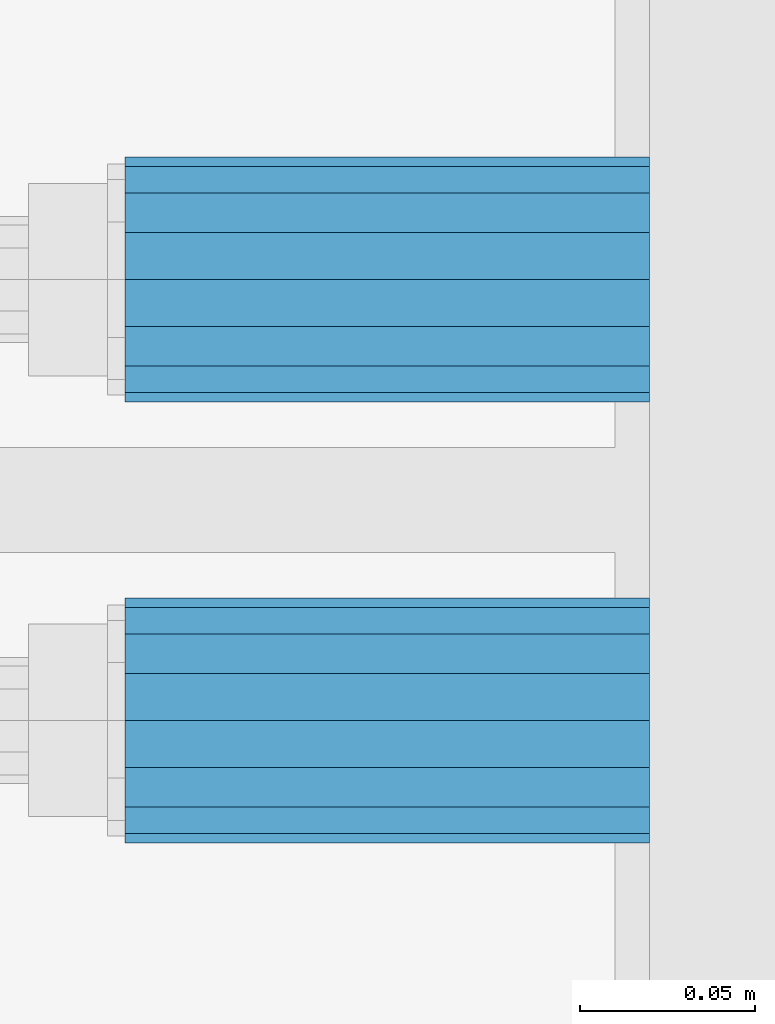
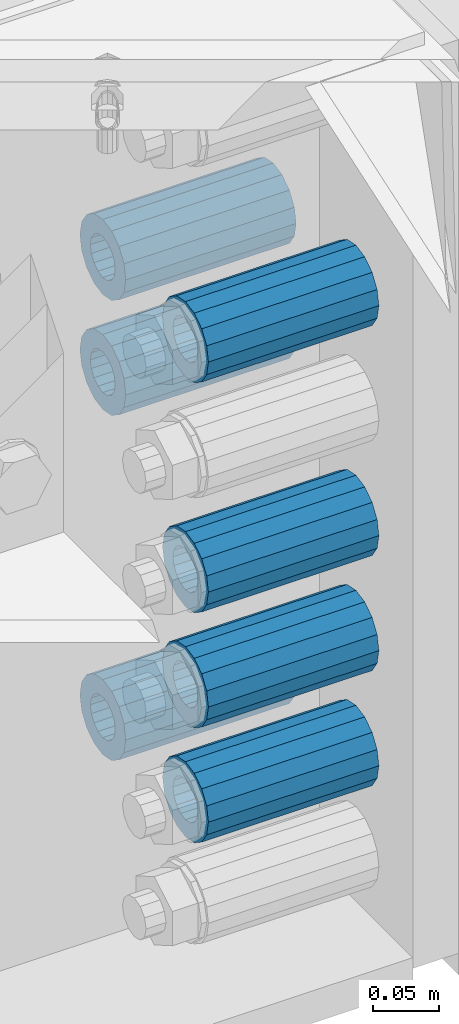
# One storey, part 163 of 257: 7 beams.
"""IFC2X3 building model written with IfcOpenShell, lengths in millimetres."""

from ifc_helpers import new_model, si_unit, frame, origin_with_axes, place, context, subcontext, project, spatial, faceted_brep, material, type_object, element, save


model = new_model("IFC2X3")

# Units and contexts
model_context = context("Model", 3, precision=1e-05, world=origin_with_axes())
body_context = subcontext(model_context, "Body", "Model", "MODEL_VIEW")
ifc_project = project(units=[si_unit("LENGTHUNIT", "METRE", prefix="MILLI"), si_unit("AREAUNIT", "SQUARE_METRE"), si_unit("VOLUMEUNIT", "CUBIC_METRE"), si_unit("MASSUNIT", "GRAM", prefix="KILO"), si_unit("TIMEUNIT", "SECOND"), si_unit("PLANEANGLEUNIT", "RADIAN"), si_unit("SOLIDANGLEUNIT", "STERADIAN"), si_unit("THERMODYNAMICTEMPERATUREUNIT", "DEGREE_CELSIUS"), si_unit("LUMINOUSINTENSITYUNIT", "LUMEN")], contexts=[model_context])

# Site, building, storey
site_placement = place(None, origin_with_axes())
site = spatial("IfcSite", under=ifc_project, at=site_placement, CompositionType="ELEMENT")
building_placement = place(site_placement, origin_with_axes())
building = spatial("IfcBuilding", under=site, at=building_placement, Name="Standard", CompositionType="ELEMENT")
storey_placement = place(building_placement, origin_with_axes())
storey = spatial("IfcBuildingStorey", under=building, at=storey_placement, Name="Undefined", CompositionType="ELEMENT", Elevation=0.0)

# Beams
ifc_material = material()
beam_type = type_object("IfcBeamType", PredefinedType="NOTDEFINED")
beam_1_placement = place(storey_placement, frame((59117.0, 3063.0, -285.0), z_axis=(0.0, 0.0, 1.0), x_axis=(1.0, 0.0, 0.0)))
element("IfcBeam", 1, at=beam_1_placement, inside=storey, type_object=beam_type, material=ifc_material, context=body_context, shape_type="Brep", body=[
    faceted_brep([(-1.3120632047503e-07, -18.9999999995493, -6.27187546342611e-09), (0.0, -17.5537111177146, 7.27098521493672), (150.0, -17.5537111177146, 7.27098521493672), (150.0, -19.0, 0.0), (0.0, -13.4350288425449, 13.4350288425444), (150.0, -13.4350288425449, 13.4350288425444), (0.0, -7.27098521493645, 17.5537111177144), (150.0, -7.27098521493645, 17.5537111177144), (-6.33792751614237e-09, 4.50654624728486e-10, 18.9999999937208), (150.0, 0.0, 19.0), (0.0, 7.27098521493645, 17.5537111177144), (150.0, 7.27098521493645, 17.5537111177144), (0.0, 13.4350288425449, 13.4350288425444), (150.0, 13.4350288425449, 13.4350288425444), (0.0, 17.5537111177146, 7.2709852149367), (150.0, 17.5537111177146, 7.2709852149367), (1.33208345687308e-07, 19.0000000004507, -6.27187546342611e-09), (150.0, 19.0, 0.0), (0.0, 17.5537111177146, -7.2709852149367), (150.0, 17.5537111177146, -7.2709852149367), (0.0, 13.4350288425449, -13.4350288425444), (150.0, 13.4350288425449, -13.4350288425444), (0.0, 7.27098521493645, -17.5537111177144), (150.0, 7.27098521493645, -17.5537111177144), (8.33983904158231e-09, 4.50654624728486e-10, -19.0000000062719), (150.0, 0.0, -19.0), (0.0, -7.27098521493645, -17.5537111177144), (150.0, -7.27098521493645, -17.5537111177144), (0.0, -13.4350288425449, -13.4350288425444), (150.0, -13.4350288425449, -13.4350288425444), (0.0, -17.5537111177146, -7.2709852149367), (150.0, -17.5537111177146, -7.2709852149367), (7.27595761418343e-12, -35.0, 0.0), (1.45519152283669e-11, -32.335783637895, -13.3939201327781), (150.0, -32.3357836378955, -13.3939201327782), (150.0, -35.0, 0.0), (7.27595761418343e-12, -24.7487373415292, -24.748737341529), (150.0, -24.7487373415288, -24.7487373415292), (7.27595761418343e-12, -13.3939201327781, -32.335783637895), (150.0, -13.3939201327785, -32.335783637895), (7.27595761418343e-12, 0.0, -35.0), (150.0, 0.0, -35.0), (7.27595761418343e-12, 13.3939201327782, -32.335783637895), (150.0, 13.3939201327785, -32.335783637895), (7.27595761418343e-12, 24.7487373415292, -24.748737341529), (150.0, 24.7487373415288, -24.7487373415292), (1.45519152283669e-11, 32.335783637895, -13.3939201327781), (150.0, 32.3357836378955, -13.3939201327781), (7.27595761418343e-12, 35.0, 0.0), (150.0, 35.0, 0.0), (7.27595761418343e-12, 32.335783637895, 13.3939201327782), (150.0, 32.3357836378955, 13.3939201327781), (7.27595761418343e-12, 24.7487373415292, 24.7487373415291), (150.0, 24.7487373415288, 24.7487373415292), (1.45519152283669e-11, 13.3939201327781, 32.335783637895), (150.0, 13.3939201327785, 32.335783637895), (1.45519152283669e-11, 0.0, 35.0000000000001), (150.0, 0.0, 35.0), (1.45519152283669e-11, -13.3939201327781, 32.335783637895), (150.0, -13.3939201327785, 32.335783637895), (7.27595761418343e-12, -24.7487373415292, 24.7487373415291), (150.0, -24.7487373415288, 24.7487373415292), (7.27595761418343e-12, -32.335783637895, 13.3939201327782), (150.0, -32.3357836378955, 13.3939201327781)], [[[0, 1, 2, 3]], [[1, 4, 5, 2]], [[4, 6, 7, 5]], [[6, 8, 9, 7]], [[8, 10, 11, 9]], [[10, 12, 13, 11]], [[12, 14, 15, 13]], [[14, 16, 17, 15]], [[16, 18, 19, 17]], [[18, 20, 21, 19]], [[20, 22, 23, 21]], [[22, 24, 25, 23]], [[24, 26, 27, 25]], [[26, 28, 29, 27]], [[28, 30, 31, 29]], [[30, 0, 3, 31]], [[32, 33, 34, 35]], [[33, 36, 37, 34]], [[36, 38, 39, 37]], [[38, 40, 41, 39]], [[40, 42, 43, 41]], [[42, 44, 45, 43]], [[44, 46, 47, 45]], [[46, 48, 49, 47]], [[48, 50, 51, 49]], [[50, 52, 53, 51]], [[52, 54, 55, 53]], [[54, 56, 57, 55]], [[56, 58, 59, 57]], [[58, 60, 61, 59]], [[60, 62, 63, 61]], [[62, 32, 35, 63]], [[37, 39, 41, 43, 45, 47, 49, 51, 53, 55, 57, 59, 61, 63, 35, 34], [5, 7, 9, 11, 13, 15, 17, 19, 21, 23, 25, 27, 29, 31, 3, 2]], [[62, 60, 58, 56, 54, 52, 50, 48, 46, 44, 42, 40, 38, 36, 33, 32], [30, 28, 26, 24, 22, 20, 18, 16, 14, 12, 10, 8, 6, 4, 1, 0]]]),
])
beam_2_placement = place(storey_placement, frame((59117.0, 2937.0, -285.0), z_axis=(0.0, 0.0, 1.0), x_axis=(1.0, 0.0, 0.0)))
element("IfcBeam", 2, at=beam_2_placement, inside=storey, type_object=beam_type, material=ifc_material, context=body_context, shape_type="Brep", body=[
    faceted_brep([(-1.3120632047503e-07, -18.9999999995493, -6.27187546342611e-09), (0.0, -17.5537111177146, 7.27098521493672), (150.0, -17.5537111177146, 7.27098521493672), (150.0, -19.0, 0.0), (0.0, -13.4350288425449, 13.4350288425444), (150.0, -13.4350288425449, 13.4350288425444), (0.0, -7.27098521493645, 17.5537111177144), (150.0, -7.27098521493645, 17.5537111177144), (-6.33792751614237e-09, 4.50654624728486e-10, 18.9999999937208), (150.0, 0.0, 19.0), (0.0, 7.27098521493645, 17.5537111177144), (150.0, 7.27098521493645, 17.5537111177144), (0.0, 13.4350288425449, 13.4350288425444), (150.0, 13.4350288425449, 13.4350288425444), (0.0, 17.5537111177146, 7.2709852149367), (150.0, 17.5537111177146, 7.2709852149367), (1.33208345687308e-07, 19.0000000004507, -6.27187546342611e-09), (150.0, 19.0, 0.0), (0.0, 17.5537111177146, -7.2709852149367), (150.0, 17.5537111177146, -7.2709852149367), (0.0, 13.4350288425449, -13.4350288425444), (150.0, 13.4350288425449, -13.4350288425444), (0.0, 7.27098521493645, -17.5537111177144), (150.0, 7.27098521493645, -17.5537111177144), (8.33983904158231e-09, 4.50654624728486e-10, -19.0000000062719), (150.0, 0.0, -19.0), (0.0, -7.27098521493645, -17.5537111177144), (150.0, -7.27098521493645, -17.5537111177144), (0.0, -13.4350288425449, -13.4350288425444), (150.0, -13.4350288425449, -13.4350288425444), (0.0, -17.5537111177146, -7.2709852149367), (150.0, -17.5537111177146, -7.2709852149367), (7.27595761418343e-12, -35.0, 0.0), (1.45519152283669e-11, -32.335783637895, -13.3939201327781), (150.0, -32.3357836378955, -13.3939201327782), (150.0, -35.0, 0.0), (7.27595761418343e-12, -24.7487373415292, -24.748737341529), (150.0, -24.7487373415288, -24.7487373415292), (7.27595761418343e-12, -13.3939201327781, -32.335783637895), (150.0, -13.3939201327785, -32.335783637895), (7.27595761418343e-12, 0.0, -35.0), (150.0, 0.0, -35.0), (7.27595761418343e-12, 13.3939201327782, -32.335783637895), (150.0, 13.3939201327785, -32.335783637895), (7.27595761418343e-12, 24.7487373415292, -24.748737341529), (150.0, 24.7487373415288, -24.7487373415292), (1.45519152283669e-11, 32.335783637895, -13.3939201327781), (150.0, 32.3357836378955, -13.3939201327781), (7.27595761418343e-12, 35.0, 0.0), (150.0, 35.0, 0.0), (7.27595761418343e-12, 32.335783637895, 13.3939201327782), (150.0, 32.3357836378955, 13.3939201327781), (7.27595761418343e-12, 24.7487373415292, 24.7487373415291), (150.0, 24.7487373415288, 24.7487373415292), (1.45519152283669e-11, 13.3939201327781, 32.335783637895), (150.0, 13.3939201327785, 32.335783637895), (1.45519152283669e-11, 0.0, 35.0000000000001), (150.0, 0.0, 35.0), (1.45519152283669e-11, -13.3939201327781, 32.335783637895), (150.0, -13.3939201327785, 32.335783637895), (7.27595761418343e-12, -24.7487373415292, 24.7487373415291), (150.0, -24.7487373415288, 24.7487373415292), (7.27595761418343e-12, -32.335783637895, 13.3939201327782), (150.0, -32.3357836378955, 13.3939201327781)], [[[0, 1, 2, 3]], [[1, 4, 5, 2]], [[4, 6, 7, 5]], [[6, 8, 9, 7]], [[8, 10, 11, 9]], [[10, 12, 13, 11]], [[12, 14, 15, 13]], [[14, 16, 17, 15]], [[16, 18, 19, 17]], [[18, 20, 21, 19]], [[20, 22, 23, 21]], [[22, 24, 25, 23]], [[24, 26, 27, 25]], [[26, 28, 29, 27]], [[28, 30, 31, 29]], [[30, 0, 3, 31]], [[32, 33, 34, 35]], [[33, 36, 37, 34]], [[36, 38, 39, 37]], [[38, 40, 41, 39]], [[40, 42, 43, 41]], [[42, 44, 45, 43]], [[44, 46, 47, 45]], [[46, 48, 49, 47]], [[48, 50, 51, 49]], [[50, 52, 53, 51]], [[52, 54, 55, 53]], [[54, 56, 57, 55]], [[56, 58, 59, 57]], [[58, 60, 61, 59]], [[60, 62, 63, 61]], [[62, 32, 35, 63]], [[37, 39, 41, 43, 45, 47, 49, 51, 53, 55, 57, 59, 61, 63, 35, 34], [5, 7, 9, 11, 13, 15, 17, 19, 21, 23, 25, 27, 29, 31, 3, 2]], [[62, 60, 58, 56, 54, 52, 50, 48, 46, 44, 42, 40, 38, 36, 33, 32], [30, 28, 26, 24, 22, 20, 18, 16, 14, 12, 10, 8, 6, 4, 1, 0]]]),
])
beam_3_placement = place(storey_placement, frame((59117.0, 2937.0, -499.0), z_axis=(0.0, 0.0, 1.0), x_axis=(1.0, 0.0, 0.0)))
element("IfcBeam", 3, at=beam_3_placement, inside=storey, type_object=beam_type, material=ifc_material, context=body_context, shape_type="Brep", body=[
    faceted_brep([(-1.3120632047503e-07, -18.9999999995493, -6.27187546342611e-09), (0.0, -17.5537111177146, 7.27098521493672), (150.0, -17.5537111177146, 7.27098521493672), (150.0, -19.0, 0.0), (0.0, -13.4350288425449, 13.4350288425444), (150.0, -13.4350288425449, 13.4350288425444), (0.0, -7.27098521493645, 17.5537111177144), (150.0, -7.27098521493645, 17.5537111177144), (-6.33792751614237e-09, 4.50654624728486e-10, 18.9999999937208), (150.0, 0.0, 19.0), (0.0, 7.27098521493645, 17.5537111177144), (150.0, 7.27098521493645, 17.5537111177144), (0.0, 13.4350288425449, 13.4350288425444), (150.0, 13.4350288425449, 13.4350288425444), (0.0, 17.5537111177146, 7.2709852149367), (150.0, 17.5537111177146, 7.2709852149367), (1.33208345687308e-07, 19.0000000004507, -6.27187546342611e-09), (150.0, 19.0, 0.0), (0.0, 17.5537111177146, -7.2709852149367), (150.0, 17.5537111177146, -7.2709852149367), (0.0, 13.4350288425449, -13.4350288425444), (150.0, 13.4350288425449, -13.4350288425444), (0.0, 7.27098521493645, -17.5537111177144), (150.0, 7.27098521493645, -17.5537111177144), (8.33983904158231e-09, 4.50654624728486e-10, -19.0000000062719), (150.0, 0.0, -19.0), (0.0, -7.27098521493645, -17.5537111177144), (150.0, -7.27098521493645, -17.5537111177144), (0.0, -13.4350288425449, -13.4350288425444), (150.0, -13.4350288425449, -13.4350288425444), (0.0, -17.5537111177146, -7.2709852149367), (150.0, -17.5537111177146, -7.2709852149367), (7.27595761418343e-12, -35.0, 0.0), (1.45519152283669e-11, -32.335783637895, -13.3939201327781), (150.0, -32.3357836378955, -13.3939201327782), (150.0, -35.0, 0.0), (7.27595761418343e-12, -24.7487373415292, -24.748737341529), (150.0, -24.7487373415288, -24.7487373415292), (7.27595761418343e-12, -13.3939201327781, -32.335783637895), (150.0, -13.3939201327785, -32.335783637895), (7.27595761418343e-12, 0.0, -35.0), (150.0, 0.0, -35.0), (7.27595761418343e-12, 13.3939201327782, -32.335783637895), (150.0, 13.3939201327785, -32.335783637895), (7.27595761418343e-12, 24.7487373415292, -24.748737341529), (150.0, 24.7487373415288, -24.7487373415292), (1.45519152283669e-11, 32.335783637895, -13.3939201327781), (150.0, 32.3357836378955, -13.3939201327781), (7.27595761418343e-12, 35.0, 0.0), (150.0, 35.0, 0.0), (7.27595761418343e-12, 32.335783637895, 13.3939201327782), (150.0, 32.3357836378955, 13.3939201327781), (7.27595761418343e-12, 24.7487373415292, 24.7487373415291), (150.0, 24.7487373415288, 24.7487373415292), (1.45519152283669e-11, 13.3939201327781, 32.335783637895), (150.0, 13.3939201327785, 32.335783637895), (1.45519152283669e-11, 0.0, 35.0000000000001), (150.0, 0.0, 35.0), (1.45519152283669e-11, -13.3939201327781, 32.335783637895), (150.0, -13.3939201327785, 32.335783637895), (7.27595761418343e-12, -24.7487373415292, 24.7487373415291), (150.0, -24.7487373415288, 24.7487373415292), (7.27595761418343e-12, -32.335783637895, 13.3939201327782), (150.0, -32.3357836378955, 13.3939201327781)], [[[0, 1, 2, 3]], [[1, 4, 5, 2]], [[4, 6, 7, 5]], [[6, 8, 9, 7]], [[8, 10, 11, 9]], [[10, 12, 13, 11]], [[12, 14, 15, 13]], [[14, 16, 17, 15]], [[16, 18, 19, 17]], [[18, 20, 21, 19]], [[20, 22, 23, 21]], [[22, 24, 25, 23]], [[24, 26, 27, 25]], [[26, 28, 29, 27]], [[28, 30, 31, 29]], [[30, 0, 3, 31]], [[32, 33, 34, 35]], [[33, 36, 37, 34]], [[36, 38, 39, 37]], [[38, 40, 41, 39]], [[40, 42, 43, 41]], [[42, 44, 45, 43]], [[44, 46, 47, 45]], [[46, 48, 49, 47]], [[48, 50, 51, 49]], [[50, 52, 53, 51]], [[52, 54, 55, 53]], [[54, 56, 57, 55]], [[56, 58, 59, 57]], [[58, 60, 61, 59]], [[60, 62, 63, 61]], [[62, 32, 35, 63]], [[37, 39, 41, 43, 45, 47, 49, 51, 53, 55, 57, 59, 61, 63, 35, 34], [5, 7, 9, 11, 13, 15, 17, 19, 21, 23, 25, 27, 29, 31, 3, 2]], [[62, 60, 58, 56, 54, 52, 50, 48, 46, 44, 42, 40, 38, 36, 33, 32], [30, 28, 26, 24, 22, 20, 18, 16, 14, 12, 10, 8, 6, 4, 1, 0]]]),
])
beam_4_placement = place(storey_placement, frame((59117.0, 2937.0, -606.0), z_axis=(0.0, 0.0, 1.0), x_axis=(1.0, 0.0, 0.0)))
element("IfcBeam", 4, at=beam_4_placement, inside=storey, type_object=beam_type, material=ifc_material, context=body_context, shape_type="Brep", body=[
    faceted_brep([(-1.3120632047503e-07, -18.9999999995493, -6.27187546342611e-09), (0.0, -17.5537111177146, 7.27098521493672), (150.0, -17.5537111177146, 7.27098521493672), (150.0, -19.0, 0.0), (0.0, -13.4350288425449, 13.4350288425444), (150.0, -13.4350288425449, 13.4350288425444), (0.0, -7.27098521493645, 17.5537111177144), (150.0, -7.27098521493645, 17.5537111177144), (-6.33792751614237e-09, 4.50654624728486e-10, 18.9999999937208), (150.0, 0.0, 19.0), (0.0, 7.27098521493645, 17.5537111177144), (150.0, 7.27098521493645, 17.5537111177144), (0.0, 13.4350288425449, 13.4350288425444), (150.0, 13.4350288425449, 13.4350288425444), (0.0, 17.5537111177146, 7.2709852149367), (150.0, 17.5537111177146, 7.2709852149367), (1.33208345687308e-07, 19.0000000004507, -6.27187546342611e-09), (150.0, 19.0, 0.0), (0.0, 17.5537111177146, -7.2709852149367), (150.0, 17.5537111177146, -7.2709852149367), (0.0, 13.4350288425449, -13.4350288425444), (150.0, 13.4350288425449, -13.4350288425444), (0.0, 7.27098521493645, -17.5537111177144), (150.0, 7.27098521493645, -17.5537111177144), (8.33983904158231e-09, 4.50654624728486e-10, -19.0000000062719), (150.0, 0.0, -19.0), (0.0, -7.27098521493645, -17.5537111177144), (150.0, -7.27098521493645, -17.5537111177144), (0.0, -13.4350288425449, -13.4350288425444), (150.0, -13.4350288425449, -13.4350288425444), (0.0, -17.5537111177146, -7.2709852149367), (150.0, -17.5537111177146, -7.2709852149367), (7.27595761418343e-12, -35.0, 0.0), (1.45519152283669e-11, -32.335783637895, -13.3939201327781), (150.0, -32.3357836378955, -13.3939201327782), (150.0, -35.0, 0.0), (7.27595761418343e-12, -24.7487373415292, -24.748737341529), (150.0, -24.7487373415288, -24.7487373415292), (7.27595761418343e-12, -13.3939201327781, -32.335783637895), (150.0, -13.3939201327785, -32.335783637895), (7.27595761418343e-12, 0.0, -35.0), (150.0, 0.0, -35.0), (7.27595761418343e-12, 13.3939201327782, -32.335783637895), (150.0, 13.3939201327785, -32.335783637895), (7.27595761418343e-12, 24.7487373415292, -24.748737341529), (150.0, 24.7487373415288, -24.7487373415292), (1.45519152283669e-11, 32.335783637895, -13.3939201327781), (150.0, 32.3357836378955, -13.3939201327781), (7.27595761418343e-12, 35.0, 0.0), (150.0, 35.0, 0.0), (7.27595761418343e-12, 32.335783637895, 13.3939201327782), (150.0, 32.3357836378955, 13.3939201327781), (7.27595761418343e-12, 24.7487373415292, 24.7487373415291), (150.0, 24.7487373415288, 24.7487373415292), (1.45519152283669e-11, 13.3939201327781, 32.335783637895), (150.0, 13.3939201327785, 32.335783637895), (1.45519152283669e-11, 0.0, 35.0000000000001), (150.0, 0.0, 35.0), (1.45519152283669e-11, -13.3939201327781, 32.335783637895), (150.0, -13.3939201327785, 32.335783637895), (7.27595761418343e-12, -24.7487373415292, 24.7487373415291), (150.0, -24.7487373415288, 24.7487373415292), (7.27595761418343e-12, -32.335783637895, 13.3939201327782), (150.0, -32.3357836378955, 13.3939201327781)], [[[0, 1, 2, 3]], [[1, 4, 5, 2]], [[4, 6, 7, 5]], [[6, 8, 9, 7]], [[8, 10, 11, 9]], [[10, 12, 13, 11]], [[12, 14, 15, 13]], [[14, 16, 17, 15]], [[16, 18, 19, 17]], [[18, 20, 21, 19]], [[20, 22, 23, 21]], [[22, 24, 25, 23]], [[24, 26, 27, 25]], [[26, 28, 29, 27]], [[28, 30, 31, 29]], [[30, 0, 3, 31]], [[32, 33, 34, 35]], [[33, 36, 37, 34]], [[36, 38, 39, 37]], [[38, 40, 41, 39]], [[40, 42, 43, 41]], [[42, 44, 45, 43]], [[44, 46, 47, 45]], [[46, 48, 49, 47]], [[48, 50, 51, 49]], [[50, 52, 53, 51]], [[52, 54, 55, 53]], [[54, 56, 57, 55]], [[56, 58, 59, 57]], [[58, 60, 61, 59]], [[60, 62, 63, 61]], [[62, 32, 35, 63]], [[37, 39, 41, 43, 45, 47, 49, 51, 53, 55, 57, 59, 61, 63, 35, 34], [5, 7, 9, 11, 13, 15, 17, 19, 21, 23, 25, 27, 29, 31, 3, 2]], [[62, 60, 58, 56, 54, 52, 50, 48, 46, 44, 42, 40, 38, 36, 33, 32], [30, 28, 26, 24, 22, 20, 18, 16, 14, 12, 10, 8, 6, 4, 1, 0]]]),
])
beam_5_placement = place(storey_placement, frame((59117.0, 3063.0, -392.0), z_axis=(0.0, 0.0, 1.0), x_axis=(1.0, 0.0, 0.0)))
element("IfcBeam", 5, at=beam_5_placement, inside=storey, type_object=beam_type, material=ifc_material, context=body_context, shape_type="Brep", body=[
    faceted_brep([(-1.3120632047503e-07, -18.9999999995493, -6.27187546342611e-09), (0.0, -17.5537111177146, 7.27098521493672), (150.0, -17.5537111177146, 7.27098521493672), (150.0, -19.0, 0.0), (0.0, -13.4350288425449, 13.4350288425444), (150.0, -13.4350288425449, 13.4350288425444), (0.0, -7.27098521493645, 17.5537111177144), (150.0, -7.27098521493645, 17.5537111177144), (-6.33792751614237e-09, 4.50654624728486e-10, 18.9999999937208), (150.0, 0.0, 19.0), (0.0, 7.27098521493645, 17.5537111177144), (150.0, 7.27098521493645, 17.5537111177144), (0.0, 13.4350288425449, 13.4350288425444), (150.0, 13.4350288425449, 13.4350288425444), (0.0, 17.5537111177146, 7.2709852149367), (150.0, 17.5537111177146, 7.2709852149367), (1.33208345687308e-07, 19.0000000004507, -6.27187546342611e-09), (150.0, 19.0, 0.0), (0.0, 17.5537111177146, -7.2709852149367), (150.0, 17.5537111177146, -7.2709852149367), (0.0, 13.4350288425449, -13.4350288425444), (150.0, 13.4350288425449, -13.4350288425444), (0.0, 7.27098521493645, -17.5537111177144), (150.0, 7.27098521493645, -17.5537111177144), (8.33983904158231e-09, 4.50654624728486e-10, -19.0000000062719), (150.0, 0.0, -19.0), (0.0, -7.27098521493645, -17.5537111177144), (150.0, -7.27098521493645, -17.5537111177144), (0.0, -13.4350288425449, -13.4350288425444), (150.0, -13.4350288425449, -13.4350288425444), (0.0, -17.5537111177146, -7.2709852149367), (150.0, -17.5537111177146, -7.2709852149367), (7.27595761418343e-12, -35.0, 0.0), (1.45519152283669e-11, -32.335783637895, -13.3939201327781), (150.0, -32.3357836378955, -13.3939201327782), (150.0, -35.0, 0.0), (7.27595761418343e-12, -24.7487373415292, -24.748737341529), (150.0, -24.7487373415288, -24.7487373415292), (7.27595761418343e-12, -13.3939201327781, -32.335783637895), (150.0, -13.3939201327785, -32.335783637895), (7.27595761418343e-12, 0.0, -35.0), (150.0, 0.0, -35.0), (7.27595761418343e-12, 13.3939201327782, -32.335783637895), (150.0, 13.3939201327785, -32.335783637895), (7.27595761418343e-12, 24.7487373415292, -24.748737341529), (150.0, 24.7487373415288, -24.7487373415292), (1.45519152283669e-11, 32.335783637895, -13.3939201327781), (150.0, 32.3357836378955, -13.3939201327781), (7.27595761418343e-12, 35.0, 0.0), (150.0, 35.0, 0.0), (7.27595761418343e-12, 32.335783637895, 13.3939201327782), (150.0, 32.3357836378955, 13.3939201327781), (7.27595761418343e-12, 24.7487373415292, 24.7487373415291), (150.0, 24.7487373415288, 24.7487373415292), (1.45519152283669e-11, 13.3939201327781, 32.335783637895), (150.0, 13.3939201327785, 32.335783637895), (1.45519152283669e-11, 0.0, 35.0000000000001), (150.0, 0.0, 35.0), (1.45519152283669e-11, -13.3939201327781, 32.335783637895), (150.0, -13.3939201327785, 32.335783637895), (7.27595761418343e-12, -24.7487373415292, 24.7487373415291), (150.0, -24.7487373415288, 24.7487373415292), (7.27595761418343e-12, -32.335783637895, 13.3939201327782), (150.0, -32.3357836378955, 13.3939201327781)], [[[0, 1, 2, 3]], [[1, 4, 5, 2]], [[4, 6, 7, 5]], [[6, 8, 9, 7]], [[8, 10, 11, 9]], [[10, 12, 13, 11]], [[12, 14, 15, 13]], [[14, 16, 17, 15]], [[16, 18, 19, 17]], [[18, 20, 21, 19]], [[20, 22, 23, 21]], [[22, 24, 25, 23]], [[24, 26, 27, 25]], [[26, 28, 29, 27]], [[28, 30, 31, 29]], [[30, 0, 3, 31]], [[32, 33, 34, 35]], [[33, 36, 37, 34]], [[36, 38, 39, 37]], [[38, 40, 41, 39]], [[40, 42, 43, 41]], [[42, 44, 45, 43]], [[44, 46, 47, 45]], [[46, 48, 49, 47]], [[48, 50, 51, 49]], [[50, 52, 53, 51]], [[52, 54, 55, 53]], [[54, 56, 57, 55]], [[56, 58, 59, 57]], [[58, 60, 61, 59]], [[60, 62, 63, 61]], [[62, 32, 35, 63]], [[37, 39, 41, 43, 45, 47, 49, 51, 53, 55, 57, 59, 61, 63, 35, 34], [5, 7, 9, 11, 13, 15, 17, 19, 21, 23, 25, 27, 29, 31, 3, 2]], [[62, 60, 58, 56, 54, 52, 50, 48, 46, 44, 42, 40, 38, 36, 33, 32], [30, 28, 26, 24, 22, 20, 18, 16, 14, 12, 10, 8, 6, 4, 1, 0]]]),
])
beam_6_placement = place(storey_placement, frame((59117.0, 3063.0, -713.0), z_axis=(0.0, 0.0, 1.0), x_axis=(1.0, 0.0, 0.0)))
element("IfcBeam", 6, at=beam_6_placement, inside=storey, type_object=beam_type, material=ifc_material, context=body_context, shape_type="Brep", body=[
    faceted_brep([(-1.3120632047503e-07, -18.9999999995493, -6.27187546342611e-09), (0.0, -17.5537111177146, 7.27098521493672), (150.0, -17.5537111177146, 7.27098521493672), (150.0, -19.0, 0.0), (0.0, -13.4350288425449, 13.4350288425444), (150.0, -13.4350288425449, 13.4350288425444), (0.0, -7.27098521493645, 17.5537111177144), (150.0, -7.27098521493645, 17.5537111177144), (-6.33792751614237e-09, 4.50654624728486e-10, 18.9999999937208), (150.0, 0.0, 19.0), (0.0, 7.27098521493645, 17.5537111177144), (150.0, 7.27098521493645, 17.5537111177144), (0.0, 13.4350288425449, 13.4350288425444), (150.0, 13.4350288425449, 13.4350288425444), (0.0, 17.5537111177146, 7.2709852149367), (150.0, 17.5537111177146, 7.2709852149367), (1.33208345687308e-07, 19.0000000004507, -6.27187546342611e-09), (150.0, 19.0, 0.0), (0.0, 17.5537111177146, -7.2709852149367), (150.0, 17.5537111177146, -7.2709852149367), (0.0, 13.4350288425449, -13.4350288425444), (150.0, 13.4350288425449, -13.4350288425444), (0.0, 7.27098521493645, -17.5537111177144), (150.0, 7.27098521493645, -17.5537111177144), (8.33983904158231e-09, 4.50654624728486e-10, -19.0000000062719), (150.0, 0.0, -19.0), (0.0, -7.27098521493645, -17.5537111177144), (150.0, -7.27098521493645, -17.5537111177144), (0.0, -13.4350288425449, -13.4350288425444), (150.0, -13.4350288425449, -13.4350288425444), (0.0, -17.5537111177146, -7.2709852149367), (150.0, -17.5537111177146, -7.2709852149367), (7.27595761418343e-12, -35.0, 0.0), (1.45519152283669e-11, -32.335783637895, -13.3939201327781), (150.0, -32.3357836378955, -13.3939201327782), (150.0, -35.0, 0.0), (7.27595761418343e-12, -24.7487373415292, -24.748737341529), (150.0, -24.7487373415288, -24.7487373415292), (7.27595761418343e-12, -13.3939201327781, -32.335783637895), (150.0, -13.3939201327785, -32.335783637895), (7.27595761418343e-12, 0.0, -35.0), (150.0, 0.0, -35.0), (7.27595761418343e-12, 13.3939201327782, -32.335783637895), (150.0, 13.3939201327785, -32.335783637895), (7.27595761418343e-12, 24.7487373415292, -24.748737341529), (150.0, 24.7487373415288, -24.7487373415292), (1.45519152283669e-11, 32.335783637895, -13.3939201327781), (150.0, 32.3357836378955, -13.3939201327781), (7.27595761418343e-12, 35.0, 0.0), (150.0, 35.0, 0.0), (7.27595761418343e-12, 32.335783637895, 13.3939201327782), (150.0, 32.3357836378955, 13.3939201327781), (7.27595761418343e-12, 24.7487373415292, 24.7487373415291), (150.0, 24.7487373415288, 24.7487373415292), (1.45519152283669e-11, 13.3939201327781, 32.335783637895), (150.0, 13.3939201327785, 32.335783637895), (1.45519152283669e-11, 0.0, 35.0000000000001), (150.0, 0.0, 35.0), (1.45519152283669e-11, -13.3939201327781, 32.335783637895), (150.0, -13.3939201327785, 32.335783637895), (7.27595761418343e-12, -24.7487373415292, 24.7487373415291), (150.0, -24.7487373415288, 24.7487373415292), (7.27595761418343e-12, -32.335783637895, 13.3939201327782), (150.0, -32.3357836378955, 13.3939201327781)], [[[0, 1, 2, 3]], [[1, 4, 5, 2]], [[4, 6, 7, 5]], [[6, 8, 9, 7]], [[8, 10, 11, 9]], [[10, 12, 13, 11]], [[12, 14, 15, 13]], [[14, 16, 17, 15]], [[16, 18, 19, 17]], [[18, 20, 21, 19]], [[20, 22, 23, 21]], [[22, 24, 25, 23]], [[24, 26, 27, 25]], [[26, 28, 29, 27]], [[28, 30, 31, 29]], [[30, 0, 3, 31]], [[32, 33, 34, 35]], [[33, 36, 37, 34]], [[36, 38, 39, 37]], [[38, 40, 41, 39]], [[40, 42, 43, 41]], [[42, 44, 45, 43]], [[44, 46, 47, 45]], [[46, 48, 49, 47]], [[48, 50, 51, 49]], [[50, 52, 53, 51]], [[52, 54, 55, 53]], [[54, 56, 57, 55]], [[56, 58, 59, 57]], [[58, 60, 61, 59]], [[60, 62, 63, 61]], [[62, 32, 35, 63]], [[37, 39, 41, 43, 45, 47, 49, 51, 53, 55, 57, 59, 61, 63, 35, 34], [5, 7, 9, 11, 13, 15, 17, 19, 21, 23, 25, 27, 29, 31, 3, 2]], [[62, 60, 58, 56, 54, 52, 50, 48, 46, 44, 42, 40, 38, 36, 33, 32], [30, 28, 26, 24, 22, 20, 18, 16, 14, 12, 10, 8, 6, 4, 1, 0]]]),
])
beam_7_placement = place(storey_placement, frame((59117.0, 2937.0, -713.0), z_axis=(0.0, 0.0, 1.0), x_axis=(1.0, 0.0, 0.0)))
element("IfcBeam", 7, at=beam_7_placement, inside=storey, type_object=beam_type, material=ifc_material, context=body_context, shape_type="Brep", body=[
    faceted_brep([(-1.3120632047503e-07, -18.9999999995493, -6.27187546342611e-09), (0.0, -17.5537111177146, 7.27098521493672), (150.0, -17.5537111177146, 7.27098521493672), (150.0, -19.0, 0.0), (0.0, -13.4350288425449, 13.4350288425444), (150.0, -13.4350288425449, 13.4350288425444), (0.0, -7.27098521493645, 17.5537111177144), (150.0, -7.27098521493645, 17.5537111177144), (-6.33792751614237e-09, 4.50654624728486e-10, 18.9999999937208), (150.0, 0.0, 19.0), (0.0, 7.27098521493645, 17.5537111177144), (150.0, 7.27098521493645, 17.5537111177144), (0.0, 13.4350288425449, 13.4350288425444), (150.0, 13.4350288425449, 13.4350288425444), (0.0, 17.5537111177146, 7.2709852149367), (150.0, 17.5537111177146, 7.2709852149367), (1.33208345687308e-07, 19.0000000004507, -6.27187546342611e-09), (150.0, 19.0, 0.0), (0.0, 17.5537111177146, -7.2709852149367), (150.0, 17.5537111177146, -7.2709852149367), (0.0, 13.4350288425449, -13.4350288425444), (150.0, 13.4350288425449, -13.4350288425444), (0.0, 7.27098521493645, -17.5537111177144), (150.0, 7.27098521493645, -17.5537111177144), (8.33983904158231e-09, 4.50654624728486e-10, -19.0000000062719), (150.0, 0.0, -19.0), (0.0, -7.27098521493645, -17.5537111177144), (150.0, -7.27098521493645, -17.5537111177144), (0.0, -13.4350288425449, -13.4350288425444), (150.0, -13.4350288425449, -13.4350288425444), (0.0, -17.5537111177146, -7.2709852149367), (150.0, -17.5537111177146, -7.2709852149367), (7.27595761418343e-12, -35.0, 0.0), (1.45519152283669e-11, -32.335783637895, -13.3939201327781), (150.0, -32.3357836378955, -13.3939201327782), (150.0, -35.0, 0.0), (7.27595761418343e-12, -24.7487373415292, -24.748737341529), (150.0, -24.7487373415288, -24.7487373415292), (7.27595761418343e-12, -13.3939201327781, -32.335783637895), (150.0, -13.3939201327785, -32.335783637895), (7.27595761418343e-12, 0.0, -35.0), (150.0, 0.0, -35.0), (7.27595761418343e-12, 13.3939201327782, -32.335783637895), (150.0, 13.3939201327785, -32.335783637895), (7.27595761418343e-12, 24.7487373415292, -24.748737341529), (150.0, 24.7487373415288, -24.7487373415292), (1.45519152283669e-11, 32.335783637895, -13.3939201327781), (150.0, 32.3357836378955, -13.3939201327781), (7.27595761418343e-12, 35.0, 0.0), (150.0, 35.0, 0.0), (7.27595761418343e-12, 32.335783637895, 13.3939201327782), (150.0, 32.3357836378955, 13.3939201327781), (7.27595761418343e-12, 24.7487373415292, 24.7487373415291), (150.0, 24.7487373415288, 24.7487373415292), (1.45519152283669e-11, 13.3939201327781, 32.335783637895), (150.0, 13.3939201327785, 32.335783637895), (1.45519152283669e-11, 0.0, 35.0000000000001), (150.0, 0.0, 35.0), (1.45519152283669e-11, -13.3939201327781, 32.335783637895), (150.0, -13.3939201327785, 32.335783637895), (7.27595761418343e-12, -24.7487373415292, 24.7487373415291), (150.0, -24.7487373415288, 24.7487373415292), (7.27595761418343e-12, -32.335783637895, 13.3939201327782), (150.0, -32.3357836378955, 13.3939201327781)], [[[0, 1, 2, 3]], [[1, 4, 5, 2]], [[4, 6, 7, 5]], [[6, 8, 9, 7]], [[8, 10, 11, 9]], [[10, 12, 13, 11]], [[12, 14, 15, 13]], [[14, 16, 17, 15]], [[16, 18, 19, 17]], [[18, 20, 21, 19]], [[20, 22, 23, 21]], [[22, 24, 25, 23]], [[24, 26, 27, 25]], [[26, 28, 29, 27]], [[28, 30, 31, 29]], [[30, 0, 3, 31]], [[32, 33, 34, 35]], [[33, 36, 37, 34]], [[36, 38, 39, 37]], [[38, 40, 41, 39]], [[40, 42, 43, 41]], [[42, 44, 45, 43]], [[44, 46, 47, 45]], [[46, 48, 49, 47]], [[48, 50, 51, 49]], [[50, 52, 53, 51]], [[52, 54, 55, 53]], [[54, 56, 57, 55]], [[56, 58, 59, 57]], [[58, 60, 61, 59]], [[60, 62, 63, 61]], [[62, 32, 35, 63]], [[37, 39, 41, 43, 45, 47, 49, 51, 53, 55, 57, 59, 61, 63, 35, 34], [5, 7, 9, 11, 13, 15, 17, 19, 21, 23, 25, 27, 29, 31, 3, 2]], [[62, 60, 58, 56, 54, 52, 50, 48, 46, 44, 42, 40, 38, 36, 33, 32], [30, 28, 26, 24, 22, 20, 18, 16, 14, 12, 10, 8, 6, 4, 1, 0]]]),
])

save(model, "model.ifc")
